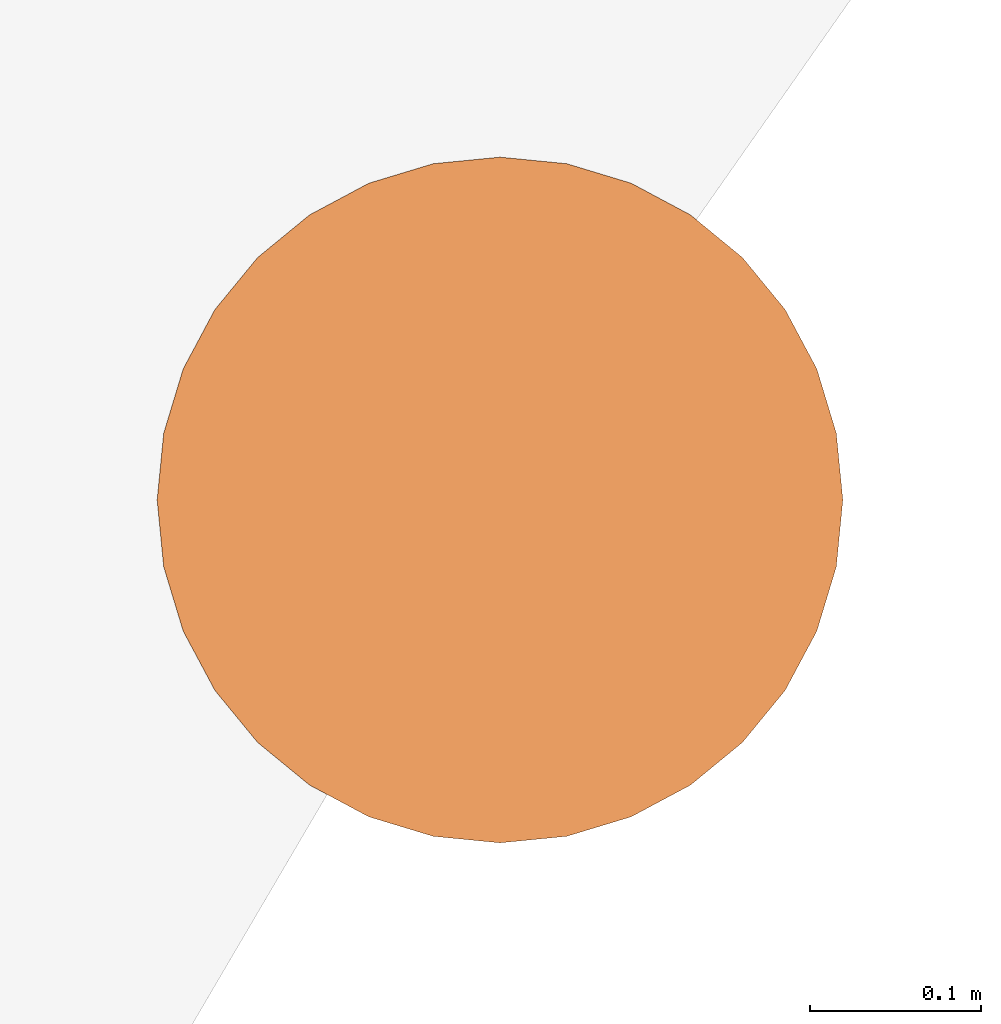
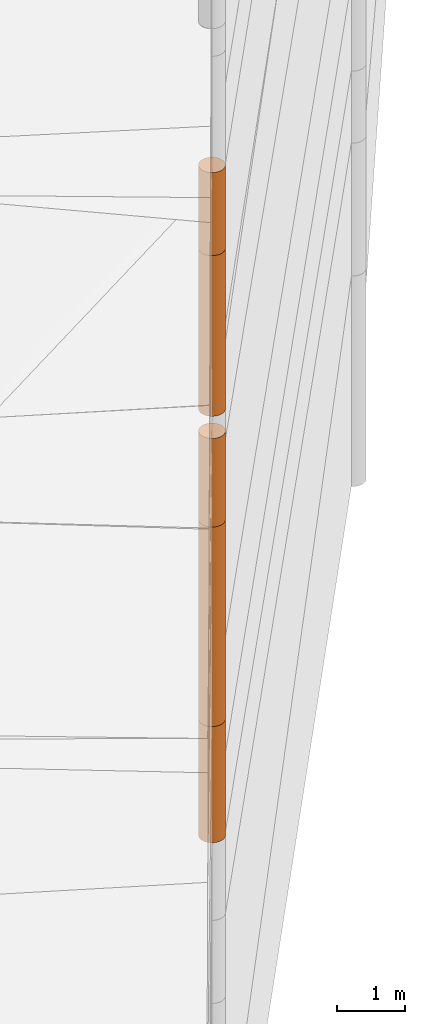
# One storey, part 6 of 24: 5 geographic elements.
"""IFC4 building model written with IfcOpenShell, lengths in metres."""

from ifc_helpers import new_model, entity, si_unit, converted_unit, frame, origin_with_axes, origin_2d_with_axis, place, context, subcontext, project, spatial, polygons, element, save


model = new_model("IFC4")

# Units and contexts
model_context = context("Model", 3, precision=1e-05, world=origin_with_axes())
plan_context = context("Plan", 2, precision=1e-05, world=origin_2d_with_axis())
body_context = subcontext(model_context, "Body", "Model", "MODEL_VIEW")
ifc_project = project(units=[converted_unit("PLANEANGLEUNIT", "degree", entity("IfcReal", 0.0174532925199433), si_unit("PLANEANGLEUNIT", "RADIAN"), dimensions=[0, 0, 0, 0, 0, 0, 0]), si_unit("AREAUNIT", "SQUARE_METRE"), si_unit("VOLUMEUNIT", "CUBIC_METRE"), si_unit("LENGTHUNIT", "METRE")], contexts=[model_context, plan_context])

# Site, building, storey
site_placement = place(None, origin_with_axes())
site = spatial("IfcSite", under=ifc_project, at=site_placement)
building_placement = place(site_placement, origin_with_axes())
building = spatial("IfcBuilding", under=site, at=building_placement, Name="Building")
storey_placement = place(building_placement, origin_with_axes())
storey = spatial("IfcBuildingStorey", under=building, at=storey_placement, Name="Storey")

# Geographic elements
geographic_element_1_placement = place(storey_placement, frame((11.5, 19.6000003814697, -1.0500009059906), z_axis=(0.0, 0.0, 1.0), x_axis=(1.0, 0.0, 0.0)))
element("IfcGeographicElement", 1, at=geographic_element_1_placement, inside=storey, PredefinedType="NOTDEFINED", context=body_context, shape_type="Tessellation", body=[
    polygons([(0.0, 0.0, -1.04999983310699), (0.0390180610120296, 0.196157038211823, -1.04999983310699), (0.0, 0.199999988079071, -1.04999983310699), (0.0, 0.0, 1.04999983310699), (0.0, 0.199999988079071, 1.04999983310699), (0.0390180610120296, 0.196157038211823, 1.04999983310699), (0.0765366926789284, 0.18477588891983, -1.04999983310699), (0.0765366926789284, 0.18477588891983, 1.04999983310699), (0.111114047467709, 0.166293919086456, -1.04999983310699), (0.111114047467709, 0.166293919086456, 1.04999983310699), (0.141421362757683, 0.141421362757683, -1.04999983310699), (0.141421362757683, 0.141421362757683, 1.04999983310699), (0.166293919086456, 0.111114047467709, -1.04999983310699), (0.166293919086456, 0.111114047467709, 1.04999983310699), (0.18477588891983, 0.0765366926789284, -1.04999983310699), (0.18477588891983, 0.0765366926789284, 1.04999983310699), (0.196157038211823, 0.0390180610120296, -1.04999983310699), (0.196157038211823, 0.0390180610120296, 1.04999983310699), (0.199999988079071, 0.0, -1.04999983310699), (0.199999988079071, 0.0, 1.04999983310699), (0.196157038211823, -0.0390180610120296, -1.04999983310699), (0.196157038211823, -0.0390180610120296, 1.04999983310699), (0.18477588891983, -0.0765366926789284, -1.04999983310699), (0.18477588891983, -0.0765366926789284, 1.04999983310699), (0.166293919086456, -0.111114047467709, -1.04999983310699), (0.166293919086456, -0.111114047467709, 1.04999983310699), (0.141421362757683, -0.141421362757683, -1.04999983310699), (0.141421362757683, -0.141421362757683, 1.04999983310699), (0.111114047467709, -0.166293919086456, -1.04999983310699), (0.111114047467709, -0.166293919086456, 1.04999983310699), (0.0765366926789284, -0.18477588891983, -1.04999983310699), (0.0765366926789284, -0.18477588891983, 1.04999983310699), (0.0390180610120296, -0.196157038211823, -1.04999983310699), (0.0390180610120296, -0.196157038211823, 1.04999983310699), (0.0, -0.199999988079071, -1.04999983310699), (0.0, -0.199999988079071, 1.04999983310699), (-0.0390180610120296, -0.196157038211823, -1.04999983310699), (-0.0390180610120296, -0.196157038211823, 1.04999983310699), (-0.0765366926789284, -0.18477588891983, -1.04999983310699), (-0.0765366926789284, -0.18477588891983, 1.04999983310699), (-0.111114047467709, -0.166293919086456, -1.04999983310699), (-0.111114047467709, -0.166293919086456, 1.04999983310699), (-0.141421362757683, -0.141421362757683, -1.04999983310699), (-0.141421362757683, -0.141421362757683, 1.04999983310699), (-0.166293919086456, -0.111114047467709, -1.04999983310699), (-0.166293919086456, -0.111114047467709, 1.04999983310699), (-0.18477588891983, -0.0765366926789284, -1.04999983310699), (-0.18477588891983, -0.0765366926789284, 1.04999983310699), (-0.196157038211823, -0.0390180610120296, -1.04999983310699), (-0.196157038211823, -0.0390180610120296, 1.04999983310699), (-0.199999988079071, 0.0, -1.04999983310699), (-0.199999988079071, 0.0, 1.04999983310699), (-0.196157038211823, 0.0390180610120296, -1.04999983310699), (-0.196157038211823, 0.0390180610120296, 1.04999983310699), (-0.18477588891983, 0.0765366926789284, -1.04999983310699), (-0.18477588891983, 0.0765366926789284, 1.04999983310699), (-0.166293919086456, 0.111114047467709, -1.04999983310699), (-0.166293919086456, 0.111114047467709, 1.04999983310699), (-0.141421362757683, 0.141421362757683, -1.04999983310699), (-0.141421362757683, 0.141421362757683, 1.04999983310699), (-0.111114047467709, 0.166293919086456, -1.04999983310699), (-0.111114047467709, 0.166293919086456, 1.04999983310699), (-0.0765366926789284, 0.18477588891983, -1.04999983310699), (-0.0765366926789284, 0.18477588891983, 1.04999983310699), (-0.0390180610120296, 0.196157038211823, -1.04999983310699), (-0.0390180610120296, 0.196157038211823, 1.04999983310699)], [[[3, 2, 1]], [[6, 5, 4]], [[34, 36, 35, 33]], [[2, 7, 1]], [[8, 6, 4]], [[54, 56, 55, 53]], [[7, 9, 1]], [[10, 8, 4]], [[10, 12, 11, 9]], [[9, 11, 1]], [[12, 10, 4]], [[11, 13, 1]], [[12, 4, 14]], [[46, 48, 47, 45]], [[1, 13, 15]], [[4, 16, 14]], [[28, 30, 29, 27]], [[1, 15, 17]], [[16, 4, 18]], [[38, 40, 39, 37]], [[1, 17, 19]], [[4, 20, 18]], [[20, 22, 21, 19]], [[1, 19, 21]], [[20, 4, 22]], [[22, 24, 23, 21]], [[1, 21, 23]], [[22, 4, 24]], [[5, 6, 2, 3]], [[1, 23, 25]], [[24, 4, 26]], [[58, 60, 59, 57]], [[1, 25, 27]], [[26, 4, 28]], [[24, 26, 25, 23]], [[1, 27, 29]], [[28, 4, 30]], [[8, 10, 9, 7]], [[1, 29, 31]], [[4, 32, 30]], [[60, 62, 61, 59]], [[1, 31, 33]], [[4, 34, 32]], [[64, 66, 65, 63]], [[1, 33, 35]], [[4, 36, 34]], [[26, 28, 27, 25]], [[1, 35, 37]], [[4, 38, 36]], [[32, 34, 33, 31]], [[1, 37, 39]], [[4, 40, 38]], [[36, 38, 37, 35]], [[1, 39, 41]], [[4, 42, 40]], [[42, 44, 43, 41]], [[43, 1, 41]], [[4, 44, 42]], [[44, 46, 45, 43]], [[45, 1, 43]], [[4, 46, 44]], [[12, 14, 13, 11]], [[47, 1, 45]], [[48, 46, 4]], [[14, 16, 15, 13]], [[49, 1, 47]], [[4, 50, 48]], [[50, 52, 51, 49]], [[51, 1, 49]], [[52, 50, 4]], [[66, 5, 3, 65]], [[51, 53, 1]], [[4, 54, 52]], [[6, 8, 7, 2]], [[55, 1, 53]], [[4, 56, 54]], [[16, 18, 17, 15]], [[55, 57, 1]], [[4, 58, 56]], [[30, 32, 31, 29]], [[59, 1, 57]], [[60, 58, 4]], [[56, 58, 57, 55]], [[59, 61, 1]], [[62, 60, 4]], [[62, 64, 63, 61]], [[61, 63, 1]], [[64, 62, 4]], [[40, 42, 41, 39]], [[63, 65, 1]], [[66, 64, 4]], [[18, 20, 19, 17]], [[65, 3, 1]], [[5, 66, 4]], [[52, 54, 53, 51]], [[48, 50, 49, 47]]]),
])
geographic_element_2_placement = place(storey_placement, frame((11.5, 19.6000003814697, 1.79999899864197), z_axis=(0.0, 0.0, 1.0), x_axis=(1.0, 0.0, 0.0)))
element("IfcGeographicElement", 2, at=geographic_element_2_placement, inside=storey, PredefinedType="NOTDEFINED", context=body_context, shape_type="Tessellation", body=[
    polygons([(0.0, 0.0, -1.79999983310699), (0.0390180610120296, 0.196157038211823, -1.79999983310699), (0.0, 0.199999988079071, -1.79999983310699), (0.0, 0.0, 1.79999983310699), (0.0, 0.199999988079071, 1.79999983310699), (0.0390180610120296, 0.196157038211823, 1.79999983310699), (0.0765366926789284, 0.18477588891983, -1.79999983310699), (0.0765366926789284, 0.18477588891983, 1.79999983310699), (0.111114047467709, 0.166293919086456, -1.79999983310699), (0.111114047467709, 0.166293919086456, 1.79999983310699), (0.141421362757683, 0.141421362757683, -1.79999983310699), (0.141421362757683, 0.141421362757683, 1.79999983310699), (0.166293919086456, 0.111114047467709, -1.79999983310699), (0.166293919086456, 0.111114047467709, 1.79999983310699), (0.18477588891983, 0.0765366926789284, -1.79999983310699), (0.18477588891983, 0.0765366926789284, 1.79999983310699), (0.196157038211823, 0.0390180610120296, -1.79999983310699), (0.196157038211823, 0.0390180610120296, 1.79999983310699), (0.199999988079071, 0.0, -1.79999983310699), (0.199999988079071, 0.0, 1.79999983310699), (0.196157038211823, -0.0390180610120296, -1.79999983310699), (0.196157038211823, -0.0390180610120296, 1.79999983310699), (0.18477588891983, -0.0765366926789284, -1.79999983310699), (0.18477588891983, -0.0765366926789284, 1.79999983310699), (0.166293919086456, -0.111114047467709, -1.79999983310699), (0.166293919086456, -0.111114047467709, 1.79999983310699), (0.141421362757683, -0.141421362757683, -1.79999983310699), (0.141421362757683, -0.141421362757683, 1.79999983310699), (0.111114047467709, -0.166293919086456, -1.79999983310699), (0.111114047467709, -0.166293919086456, 1.79999983310699), (0.0765366926789284, -0.18477588891983, -1.79999983310699), (0.0765366926789284, -0.18477588891983, 1.79999983310699), (0.0390180610120296, -0.196157038211823, -1.79999983310699), (0.0390180610120296, -0.196157038211823, 1.79999983310699), (0.0, -0.199999988079071, -1.79999983310699), (0.0, -0.199999988079071, 1.79999983310699), (-0.0390180610120296, -0.196157038211823, -1.79999983310699), (-0.0390180610120296, -0.196157038211823, 1.79999983310699), (-0.0765366926789284, -0.18477588891983, -1.79999983310699), (-0.0765366926789284, -0.18477588891983, 1.79999983310699), (-0.111114047467709, -0.166293919086456, -1.79999983310699), (-0.111114047467709, -0.166293919086456, 1.79999983310699), (-0.141421362757683, -0.141421362757683, -1.79999983310699), (-0.141421362757683, -0.141421362757683, 1.79999983310699), (-0.166293919086456, -0.111114047467709, -1.79999983310699), (-0.166293919086456, -0.111114047467709, 1.79999983310699), (-0.18477588891983, -0.0765366926789284, -1.79999983310699), (-0.18477588891983, -0.0765366926789284, 1.79999983310699), (-0.196157038211823, -0.0390180610120296, -1.79999983310699), (-0.196157038211823, -0.0390180610120296, 1.79999983310699), (-0.199999988079071, 0.0, -1.79999983310699), (-0.199999988079071, 0.0, 1.79999983310699), (-0.196157038211823, 0.0390180610120296, -1.79999983310699), (-0.196157038211823, 0.0390180610120296, 1.79999983310699), (-0.18477588891983, 0.0765366926789284, -1.79999983310699), (-0.18477588891983, 0.0765366926789284, 1.79999983310699), (-0.166293919086456, 0.111114047467709, -1.79999983310699), (-0.166293919086456, 0.111114047467709, 1.79999983310699), (-0.141421362757683, 0.141421362757683, -1.79999983310699), (-0.141421362757683, 0.141421362757683, 1.79999983310699), (-0.111114047467709, 0.166293919086456, -1.79999983310699), (-0.111114047467709, 0.166293919086456, 1.79999983310699), (-0.0765366926789284, 0.18477588891983, -1.79999983310699), (-0.0765366926789284, 0.18477588891983, 1.79999983310699), (-0.0390180610120296, 0.196157038211823, -1.79999983310699), (-0.0390180610120296, 0.196157038211823, 1.79999983310699)], [[[3, 2, 1]], [[6, 5, 4]], [[32, 34, 33, 31]], [[2, 7, 1]], [[8, 6, 4]], [[64, 66, 65, 63]], [[7, 9, 1]], [[10, 8, 4]], [[9, 11, 1]], [[12, 10, 4]], [[40, 42, 41, 39]], [[1, 11, 13]], [[12, 4, 14]], [[10, 12, 11, 9]], [[1, 13, 15]], [[4, 16, 14]], [[12, 14, 13, 11]], [[1, 15, 17]], [[4, 18, 16]], [[18, 20, 19, 17]], [[1, 17, 19]], [[4, 20, 18]], [[20, 22, 21, 19]], [[1, 19, 21]], [[20, 4, 22]], [[22, 24, 23, 21]], [[1, 21, 23]], [[4, 24, 22]], [[54, 56, 55, 53]], [[1, 23, 25]], [[4, 26, 24]], [[56, 58, 57, 55]], [[27, 1, 25]], [[4, 28, 26]], [[24, 26, 25, 23]], [[1, 27, 29]], [[28, 4, 30]], [[26, 28, 27, 25]], [[1, 29, 31]], [[4, 32, 30]], [[46, 48, 47, 45]], [[1, 31, 33]], [[4, 34, 32]], [[36, 38, 37, 35]], [[1, 33, 35]], [[4, 36, 34]], [[42, 44, 43, 41]], [[1, 35, 37]], [[4, 38, 36]], [[38, 40, 39, 37]], [[1, 37, 39]], [[4, 40, 38]], [[34, 36, 35, 33]], [[1, 39, 41]], [[4, 42, 40]], [[8, 10, 9, 7]], [[43, 1, 41]], [[4, 44, 42]], [[44, 46, 45, 43]], [[43, 45, 1]], [[46, 44, 4]], [[30, 32, 31, 29]], [[45, 47, 1]], [[48, 46, 4]], [[28, 30, 29, 27]], [[47, 49, 1]], [[50, 48, 4]], [[5, 6, 2, 3]], [[51, 1, 49]], [[52, 50, 4]], [[48, 50, 49, 47]], [[51, 53, 1]], [[4, 54, 52]], [[50, 52, 51, 49]], [[53, 55, 1]], [[56, 54, 4]], [[52, 54, 53, 51]], [[55, 57, 1]], [[58, 56, 4]], [[58, 60, 59, 57]], [[57, 59, 1]], [[60, 58, 4]], [[60, 62, 61, 59]], [[59, 61, 1]], [[62, 60, 4]], [[62, 64, 63, 61]], [[61, 63, 1]], [[64, 62, 4]], [[14, 16, 15, 13]], [[63, 65, 1]], [[66, 64, 4]], [[16, 18, 17, 15]], [[65, 3, 1]], [[5, 66, 4]], [[6, 8, 7, 2]], [[66, 5, 3, 65]]]),
])
geographic_element_3_placement = place(storey_placement, frame((11.5, 19.6000003814697, 9.24999904632568), z_axis=(0.0, 0.0, 1.0), x_axis=(1.0, 0.0, 0.0)))
element("IfcGeographicElement", 3, at=geographic_element_3_placement, inside=storey, PredefinedType="NOTDEFINED", context=body_context, shape_type="Tessellation", body=[
    polygons([(0.0, 0.0, -0.749999940395355), (0.0390180610120296, 0.196157038211823, -0.749999940395355), (0.0, 0.199999988079071, -0.749999940395355), (0.0, 0.0, 0.749999940395355), (0.0, 0.199999988079071, 0.749999940395355), (0.0390180610120296, 0.196157038211823, 0.749999940395355), (0.0765366926789284, 0.18477588891983, -0.749999940395355), (0.0765366926789284, 0.18477588891983, 0.749999940395355), (0.111114047467709, 0.166293919086456, -0.749999940395355), (0.111114047467709, 0.166293919086456, 0.749999940395355), (0.141421362757683, 0.141421362757683, -0.749999940395355), (0.141421362757683, 0.141421362757683, 0.749999940395355), (0.166293919086456, 0.111114047467709, -0.749999940395355), (0.166293919086456, 0.111114047467709, 0.749999940395355), (0.18477588891983, 0.0765366926789284, -0.749999940395355), (0.18477588891983, 0.0765366926789284, 0.749999940395355), (0.196157038211823, 0.0390180610120296, -0.749999940395355), (0.196157038211823, 0.0390180610120296, 0.749999940395355), (0.199999988079071, 0.0, -0.749999940395355), (0.199999988079071, 0.0, 0.749999940395355), (0.196157038211823, -0.0390180610120296, -0.749999940395355), (0.196157038211823, -0.0390180610120296, 0.749999940395355), (0.18477588891983, -0.0765366926789284, -0.749999940395355), (0.18477588891983, -0.0765366926789284, 0.749999940395355), (0.166293919086456, -0.111114047467709, -0.749999940395355), (0.166293919086456, -0.111114047467709, 0.749999940395355), (0.141421362757683, -0.141421362757683, -0.749999940395355), (0.141421362757683, -0.141421362757683, 0.749999940395355), (0.111114047467709, -0.166293919086456, -0.749999940395355), (0.111114047467709, -0.166293919086456, 0.749999940395355), (0.0765366926789284, -0.18477588891983, -0.749999940395355), (0.0765366926789284, -0.18477588891983, 0.749999940395355), (0.0390180610120296, -0.196157038211823, -0.749999940395355), (0.0390180610120296, -0.196157038211823, 0.749999940395355), (0.0, -0.199999988079071, -0.749999940395355), (0.0, -0.199999988079071, 0.749999940395355), (-0.0390180610120296, -0.196157038211823, -0.749999940395355), (-0.0390180610120296, -0.196157038211823, 0.749999940395355), (-0.0765366926789284, -0.18477588891983, -0.749999940395355), (-0.0765366926789284, -0.18477588891983, 0.749999940395355), (-0.111114047467709, -0.166293919086456, -0.749999940395355), (-0.111114047467709, -0.166293919086456, 0.749999940395355), (-0.141421362757683, -0.141421362757683, -0.749999940395355), (-0.141421362757683, -0.141421362757683, 0.749999940395355), (-0.166293919086456, -0.111114047467709, -0.749999940395355), (-0.166293919086456, -0.111114047467709, 0.749999940395355), (-0.18477588891983, -0.0765366926789284, -0.749999940395355), (-0.18477588891983, -0.0765366926789284, 0.749999940395355), (-0.196157038211823, -0.0390180610120296, -0.749999940395355), (-0.196157038211823, -0.0390180610120296, 0.749999940395355), (-0.199999988079071, 0.0, -0.749999940395355), (-0.199999988079071, 0.0, 0.749999940395355), (-0.196157038211823, 0.0390180610120296, -0.749999940395355), (-0.196157038211823, 0.0390180610120296, 0.749999940395355), (-0.18477588891983, 0.0765366926789284, -0.749999940395355), (-0.18477588891983, 0.0765366926789284, 0.749999940395355), (-0.166293919086456, 0.111114047467709, -0.749999940395355), (-0.166293919086456, 0.111114047467709, 0.749999940395355), (-0.141421362757683, 0.141421362757683, -0.749999940395355), (-0.141421362757683, 0.141421362757683, 0.749999940395355), (-0.111114047467709, 0.166293919086456, -0.749999940395355), (-0.111114047467709, 0.166293919086456, 0.749999940395355), (-0.0765366926789284, 0.18477588891983, -0.749999940395355), (-0.0765366926789284, 0.18477588891983, 0.749999940395355), (-0.0390180610120296, 0.196157038211823, -0.749999940395355), (-0.0390180610120296, 0.196157038211823, 0.749999940395355)], [[[3, 2, 1]], [[6, 5, 4]], [[28, 30, 29, 27]], [[2, 7, 1]], [[8, 6, 4]], [[36, 38, 37, 35]], [[7, 9, 1]], [[10, 8, 4]], [[56, 58, 57, 55]], [[9, 11, 1]], [[12, 10, 4]], [[58, 60, 59, 57]], [[11, 13, 1]], [[12, 4, 14]], [[54, 56, 55, 53]], [[1, 13, 15]], [[4, 16, 14]], [[10, 12, 11, 9]], [[1, 15, 17]], [[4, 18, 16]], [[60, 62, 61, 59]], [[1, 17, 19]], [[4, 20, 18]], [[16, 18, 17, 15]], [[1, 19, 21]], [[20, 4, 22]], [[18, 20, 19, 17]], [[1, 21, 23]], [[4, 24, 22]], [[20, 22, 21, 19]], [[1, 23, 25]], [[24, 4, 26]], [[22, 24, 23, 21]], [[1, 25, 27]], [[26, 4, 28]], [[24, 26, 25, 23]], [[1, 27, 29]], [[28, 4, 30]], [[62, 64, 63, 61]], [[1, 29, 31]], [[4, 32, 30]], [[64, 66, 65, 63]], [[1, 31, 33]], [[4, 34, 32]], [[30, 32, 31, 29]], [[1, 33, 35]], [[4, 36, 34]], [[8, 10, 9, 7]], [[1, 35, 37]], [[4, 38, 36]], [[32, 34, 33, 31]], [[1, 37, 39]], [[4, 40, 38]], [[6, 8, 7, 2]], [[1, 39, 41]], [[4, 42, 40]], [[38, 40, 39, 37]], [[43, 1, 41]], [[4, 44, 42]], [[40, 42, 41, 39]], [[45, 1, 43]], [[4, 46, 44]], [[42, 44, 43, 41]], [[47, 1, 45]], [[48, 46, 4]], [[44, 46, 45, 43]], [[47, 49, 1]], [[50, 48, 4]], [[46, 48, 47, 45]], [[51, 1, 49]], [[52, 50, 4]], [[48, 50, 49, 47]], [[51, 53, 1]], [[4, 54, 52]], [[66, 5, 3, 65]], [[53, 55, 1]], [[56, 54, 4]], [[52, 54, 53, 51]], [[55, 57, 1]], [[4, 58, 56]], [[59, 1, 57]], [[60, 58, 4]], [[34, 36, 35, 33]], [[59, 61, 1]], [[62, 60, 4]], [[14, 16, 15, 13]], [[61, 63, 1]], [[64, 62, 4]], [[26, 28, 27, 25]], [[63, 65, 1]], [[66, 64, 4]], [[5, 6, 2, 3]], [[65, 3, 1]], [[5, 66, 4]], [[50, 52, 51, 49]], [[12, 14, 13, 11]]]),
])
geographic_element_4_placement = place(storey_placement, frame((11.5, 19.6000003814697, 4.39999914169312), z_axis=(0.0, 0.0, 1.0), x_axis=(1.0, 0.0, 0.0)))
element("IfcGeographicElement", 4, at=geographic_element_4_placement, inside=storey, PredefinedType="NOTDEFINED", context=body_context, shape_type="Tessellation", body=[
    polygons([(0.0, 0.0, -0.799999952316284), (0.0390180610120296, 0.196157038211823, -0.799999952316284), (0.0, 0.199999988079071, -0.799999952316284), (0.0, 0.0, 0.799999952316284), (0.0, 0.199999988079071, 0.799999952316284), (0.0390180610120296, 0.196157038211823, 0.799999952316284), (0.0765366926789284, 0.18477588891983, -0.799999952316284), (0.0765366926789284, 0.18477588891983, 0.799999952316284), (0.111114047467709, 0.166293919086456, -0.799999952316284), (0.111114047467709, 0.166293919086456, 0.799999952316284), (0.141421362757683, 0.141421362757683, -0.799999952316284), (0.141421362757683, 0.141421362757683, 0.799999952316284), (0.166293919086456, 0.111114047467709, -0.799999952316284), (0.166293919086456, 0.111114047467709, 0.799999952316284), (0.18477588891983, 0.0765366926789284, -0.799999952316284), (0.18477588891983, 0.0765366926789284, 0.799999952316284), (0.196157038211823, 0.0390180610120296, -0.799999952316284), (0.196157038211823, 0.0390180610120296, 0.799999952316284), (0.199999988079071, 0.0, -0.799999952316284), (0.199999988079071, 0.0, 0.799999952316284), (0.196157038211823, -0.0390180610120296, -0.799999952316284), (0.196157038211823, -0.0390180610120296, 0.799999952316284), (0.18477588891983, -0.0765366926789284, -0.799999952316284), (0.18477588891983, -0.0765366926789284, 0.799999952316284), (0.166293919086456, -0.111114047467709, -0.799999952316284), (0.166293919086456, -0.111114047467709, 0.799999952316284), (0.141421362757683, -0.141421362757683, -0.799999952316284), (0.141421362757683, -0.141421362757683, 0.799999952316284), (0.111114047467709, -0.166293919086456, -0.799999952316284), (0.111114047467709, -0.166293919086456, 0.799999952316284), (0.0765366926789284, -0.18477588891983, -0.799999952316284), (0.0765366926789284, -0.18477588891983, 0.799999952316284), (0.0390180610120296, -0.196157038211823, -0.799999952316284), (0.0390180610120296, -0.196157038211823, 0.799999952316284), (0.0, -0.199999988079071, -0.799999952316284), (0.0, -0.199999988079071, 0.799999952316284), (-0.0390180610120296, -0.196157038211823, -0.799999952316284), (-0.0390180610120296, -0.196157038211823, 0.799999952316284), (-0.0765366926789284, -0.18477588891983, -0.799999952316284), (-0.0765366926789284, -0.18477588891983, 0.799999952316284), (-0.111114047467709, -0.166293919086456, -0.799999952316284), (-0.111114047467709, -0.166293919086456, 0.799999952316284), (-0.141421362757683, -0.141421362757683, -0.799999952316284), (-0.141421362757683, -0.141421362757683, 0.799999952316284), (-0.166293919086456, -0.111114047467709, -0.799999952316284), (-0.166293919086456, -0.111114047467709, 0.799999952316284), (-0.18477588891983, -0.0765366926789284, -0.799999952316284), (-0.18477588891983, -0.0765366926789284, 0.799999952316284), (-0.196157038211823, -0.0390180610120296, -0.799999952316284), (-0.196157038211823, -0.0390180610120296, 0.799999952316284), (-0.199999988079071, 0.0, -0.799999952316284), (-0.199999988079071, 0.0, 0.799999952316284), (-0.196157038211823, 0.0390180610120296, -0.799999952316284), (-0.196157038211823, 0.0390180610120296, 0.799999952316284), (-0.18477588891983, 0.0765366926789284, -0.799999952316284), (-0.18477588891983, 0.0765366926789284, 0.799999952316284), (-0.166293919086456, 0.111114047467709, -0.799999952316284), (-0.166293919086456, 0.111114047467709, 0.799999952316284), (-0.141421362757683, 0.141421362757683, -0.799999952316284), (-0.141421362757683, 0.141421362757683, 0.799999952316284), (-0.111114047467709, 0.166293919086456, -0.799999952316284), (-0.111114047467709, 0.166293919086456, 0.799999952316284), (-0.0765366926789284, 0.18477588891983, -0.799999952316284), (-0.0765366926789284, 0.18477588891983, 0.799999952316284), (-0.0390180610120296, 0.196157038211823, -0.799999952316284), (-0.0390180610120296, 0.196157038211823, 0.799999952316284)], [[[3, 2, 1]], [[6, 5, 4]], [[28, 30, 29, 27]], [[2, 7, 1]], [[8, 6, 4]], [[36, 38, 37, 35]], [[7, 9, 1]], [[10, 8, 4]], [[56, 58, 57, 55]], [[9, 11, 1]], [[12, 10, 4]], [[58, 60, 59, 57]], [[11, 13, 1]], [[12, 4, 14]], [[54, 56, 55, 53]], [[1, 13, 15]], [[14, 4, 16]], [[10, 12, 11, 9]], [[1, 15, 17]], [[4, 18, 16]], [[60, 62, 61, 59]], [[1, 17, 19]], [[4, 20, 18]], [[16, 18, 17, 15]], [[1, 19, 21]], [[4, 22, 20]], [[18, 20, 19, 17]], [[1, 21, 23]], [[4, 24, 22]], [[20, 22, 21, 19]], [[1, 23, 25]], [[24, 4, 26]], [[22, 24, 23, 21]], [[27, 1, 25]], [[26, 4, 28]], [[24, 26, 25, 23]], [[1, 27, 29]], [[28, 4, 30]], [[62, 64, 63, 61]], [[1, 29, 31]], [[4, 32, 30]], [[64, 66, 65, 63]], [[1, 31, 33]], [[4, 34, 32]], [[30, 32, 31, 29]], [[1, 33, 35]], [[4, 36, 34]], [[8, 10, 9, 7]], [[1, 35, 37]], [[4, 38, 36]], [[32, 34, 33, 31]], [[1, 37, 39]], [[4, 40, 38]], [[6, 8, 7, 2]], [[1, 39, 41]], [[4, 42, 40]], [[38, 40, 39, 37]], [[43, 1, 41]], [[4, 44, 42]], [[40, 42, 41, 39]], [[45, 1, 43]], [[46, 44, 4]], [[42, 44, 43, 41]], [[47, 1, 45]], [[4, 48, 46]], [[44, 46, 45, 43]], [[47, 49, 1]], [[50, 48, 4]], [[46, 48, 47, 45]], [[49, 51, 1]], [[52, 50, 4]], [[48, 50, 49, 47]], [[51, 53, 1]], [[54, 52, 4]], [[66, 5, 3, 65]], [[53, 55, 1]], [[56, 54, 4]], [[52, 54, 53, 51]], [[57, 1, 55]], [[4, 58, 56]], [[57, 59, 1]], [[60, 58, 4]], [[34, 36, 35, 33]], [[59, 61, 1]], [[62, 60, 4]], [[14, 16, 15, 13]], [[61, 63, 1]], [[64, 62, 4]], [[26, 28, 27, 25]], [[63, 65, 1]], [[66, 64, 4]], [[5, 6, 2, 3]], [[65, 3, 1]], [[5, 66, 4]], [[50, 52, 51, 49]], [[12, 14, 13, 11]]]),
])
geographic_element_5_placement = place(storey_placement, frame((11.5, 19.6000003814697, 7.04999923706055), z_axis=(0.0, 0.0, 1.0), x_axis=(1.0, 0.0, 0.0)))
element("IfcGeographicElement", 5, at=geographic_element_5_placement, inside=storey, PredefinedType="NOTDEFINED", context=body_context, shape_type="Tessellation", body=[
    polygons([(0.0, 0.0, -1.45000004768372), (0.0390180610120296, 0.196157038211823, -1.45000004768372), (0.0, 0.199999988079071, -1.45000004768372), (0.0, 0.0, 1.45000004768372), (0.0, 0.199999988079071, 1.45000004768372), (0.0390180610120296, 0.196157038211823, 1.45000004768372), (0.0765366926789284, 0.18477588891983, -1.45000004768372), (0.0765366926789284, 0.18477588891983, 1.45000004768372), (0.111114047467709, 0.166293919086456, -1.45000004768372), (0.111114047467709, 0.166293919086456, 1.45000004768372), (0.141421362757683, 0.141421362757683, -1.45000004768372), (0.141421362757683, 0.141421362757683, 1.45000004768372), (0.166293919086456, 0.111114047467709, -1.45000004768372), (0.166293919086456, 0.111114047467709, 1.45000004768372), (0.18477588891983, 0.0765366926789284, -1.45000004768372), (0.18477588891983, 0.0765366926789284, 1.45000004768372), (0.196157038211823, 0.0390180610120296, -1.45000004768372), (0.196157038211823, 0.0390180610120296, 1.45000004768372), (0.199999988079071, 0.0, -1.45000004768372), (0.199999988079071, 0.0, 1.45000004768372), (0.196157038211823, -0.0390180610120296, -1.45000004768372), (0.196157038211823, -0.0390180610120296, 1.45000004768372), (0.18477588891983, -0.0765366926789284, -1.45000004768372), (0.18477588891983, -0.0765366926789284, 1.45000004768372), (0.166293919086456, -0.111114047467709, -1.45000004768372), (0.166293919086456, -0.111114047467709, 1.45000004768372), (0.141421362757683, -0.141421362757683, -1.45000004768372), (0.141421362757683, -0.141421362757683, 1.45000004768372), (0.111114047467709, -0.166293919086456, -1.45000004768372), (0.111114047467709, -0.166293919086456, 1.45000004768372), (0.0765366926789284, -0.18477588891983, -1.45000004768372), (0.0765366926789284, -0.18477588891983, 1.45000004768372), (0.0390180610120296, -0.196157038211823, -1.45000004768372), (0.0390180610120296, -0.196157038211823, 1.45000004768372), (0.0, -0.199999988079071, -1.45000004768372), (0.0, -0.199999988079071, 1.45000004768372), (-0.0390180610120296, -0.196157038211823, -1.45000004768372), (-0.0390180610120296, -0.196157038211823, 1.45000004768372), (-0.0765366926789284, -0.18477588891983, -1.45000004768372), (-0.0765366926789284, -0.18477588891983, 1.45000004768372), (-0.111114047467709, -0.166293919086456, -1.45000004768372), (-0.111114047467709, -0.166293919086456, 1.45000004768372), (-0.141421362757683, -0.141421362757683, -1.45000004768372), (-0.141421362757683, -0.141421362757683, 1.45000004768372), (-0.166293919086456, -0.111114047467709, -1.45000004768372), (-0.166293919086456, -0.111114047467709, 1.45000004768372), (-0.18477588891983, -0.0765366926789284, -1.45000004768372), (-0.18477588891983, -0.0765366926789284, 1.45000004768372), (-0.196157038211823, -0.0390180610120296, -1.45000004768372), (-0.196157038211823, -0.0390180610120296, 1.45000004768372), (-0.199999988079071, 0.0, -1.45000004768372), (-0.199999988079071, 0.0, 1.45000004768372), (-0.196157038211823, 0.0390180610120296, -1.45000004768372), (-0.196157038211823, 0.0390180610120296, 1.45000004768372), (-0.18477588891983, 0.0765366926789284, -1.45000004768372), (-0.18477588891983, 0.0765366926789284, 1.45000004768372), (-0.166293919086456, 0.111114047467709, -1.45000004768372), (-0.166293919086456, 0.111114047467709, 1.45000004768372), (-0.141421362757683, 0.141421362757683, -1.45000004768372), (-0.141421362757683, 0.141421362757683, 1.45000004768372), (-0.111114047467709, 0.166293919086456, -1.45000004768372), (-0.111114047467709, 0.166293919086456, 1.45000004768372), (-0.0765366926789284, 0.18477588891983, -1.45000004768372), (-0.0765366926789284, 0.18477588891983, 1.45000004768372), (-0.0390180610120296, 0.196157038211823, -1.45000004768372), (-0.0390180610120296, 0.196157038211823, 1.45000004768372)], [[[3, 2, 1]], [[6, 5, 4]], [[32, 34, 33, 31]], [[2, 7, 1]], [[8, 6, 4]], [[64, 66, 65, 63]], [[7, 9, 1]], [[10, 8, 4]], [[9, 11, 1]], [[12, 10, 4]], [[40, 42, 41, 39]], [[1, 11, 13]], [[12, 4, 14]], [[10, 12, 11, 9]], [[1, 13, 15]], [[14, 4, 16]], [[12, 14, 13, 11]], [[1, 15, 17]], [[16, 4, 18]], [[18, 20, 19, 17]], [[1, 17, 19]], [[4, 20, 18]], [[20, 22, 21, 19]], [[1, 19, 21]], [[4, 22, 20]], [[22, 24, 23, 21]], [[1, 21, 23]], [[22, 4, 24]], [[54, 56, 55, 53]], [[1, 23, 25]], [[24, 4, 26]], [[56, 58, 57, 55]], [[1, 25, 27]], [[4, 28, 26]], [[24, 26, 25, 23]], [[1, 27, 29]], [[28, 4, 30]], [[26, 28, 27, 25]], [[1, 29, 31]], [[4, 32, 30]], [[46, 48, 47, 45]], [[1, 31, 33]], [[4, 34, 32]], [[36, 38, 37, 35]], [[1, 33, 35]], [[4, 36, 34]], [[42, 44, 43, 41]], [[1, 35, 37]], [[4, 38, 36]], [[38, 40, 39, 37]], [[1, 37, 39]], [[4, 40, 38]], [[34, 36, 35, 33]], [[1, 39, 41]], [[4, 42, 40]], [[8, 10, 9, 7]], [[43, 1, 41]], [[4, 44, 42]], [[44, 46, 45, 43]], [[43, 45, 1]], [[4, 46, 44]], [[30, 32, 31, 29]], [[47, 1, 45]], [[4, 48, 46]], [[28, 30, 29, 27]], [[49, 1, 47]], [[4, 50, 48]], [[5, 6, 2, 3]], [[49, 51, 1]], [[52, 50, 4]], [[48, 50, 49, 47]], [[51, 53, 1]], [[54, 52, 4]], [[50, 52, 51, 49]], [[55, 1, 53]], [[4, 56, 54]], [[52, 54, 53, 51]], [[57, 1, 55]], [[4, 58, 56]], [[58, 60, 59, 57]], [[59, 1, 57]], [[60, 58, 4]], [[60, 62, 61, 59]], [[59, 61, 1]], [[62, 60, 4]], [[62, 64, 63, 61]], [[61, 63, 1]], [[64, 62, 4]], [[14, 16, 15, 13]], [[63, 65, 1]], [[66, 64, 4]], [[16, 18, 17, 15]], [[65, 3, 1]], [[5, 66, 4]], [[6, 8, 7, 2]], [[66, 5, 3, 65]]]),
])

save(model, "model.ifc")
